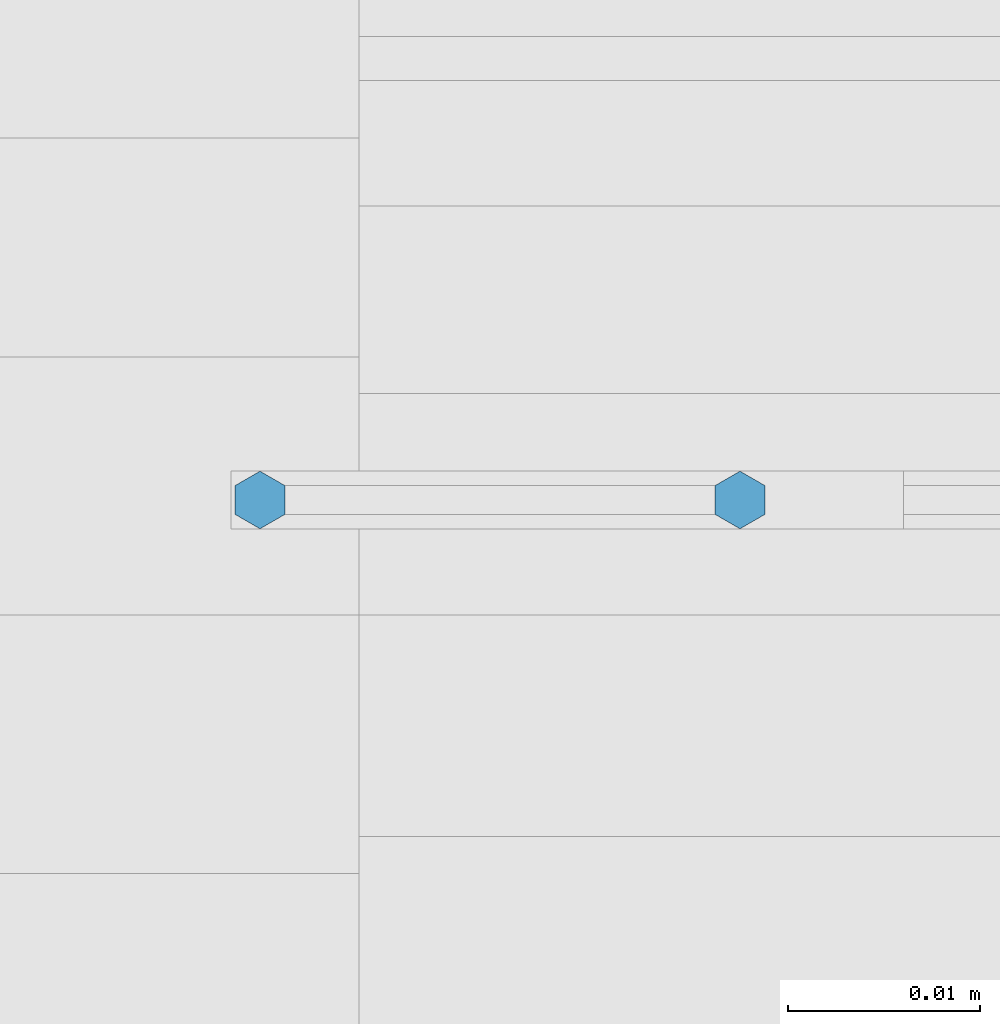
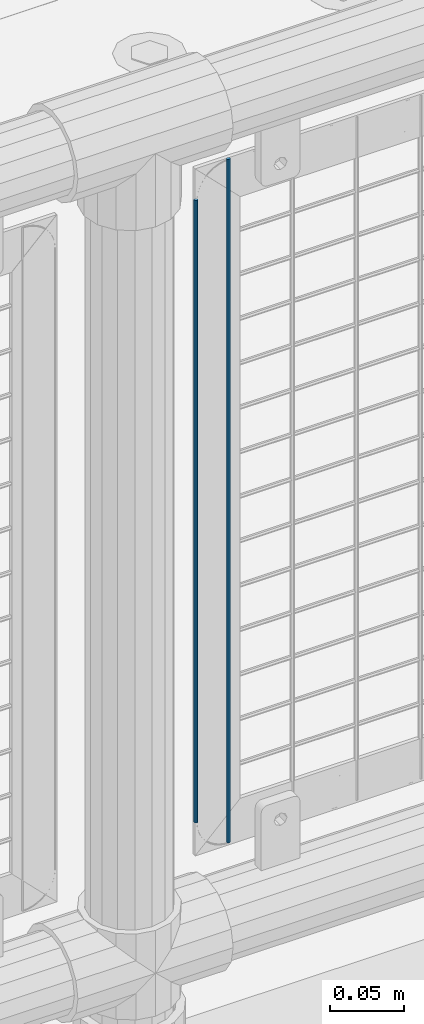
# One storey, part 69 of 208: 2 columns.
"""IFC2X3 building model written with IfcOpenShell, lengths in millimetres."""

from ifc_helpers import new_model, si_unit, frame, origin_with_axes, place, context, subcontext, project, spatial, faceted_brep, material, type_object, element, save


model = new_model("IFC2X3")

# Units and contexts
model_context = context("Model", 3, precision=1e-05, world=origin_with_axes())
body_context = subcontext(model_context, "Body", "Model", "MODEL_VIEW")
ifc_project = project(units=[si_unit("LENGTHUNIT", "METRE", prefix="MILLI"), si_unit("AREAUNIT", "SQUARE_METRE"), si_unit("VOLUMEUNIT", "CUBIC_METRE"), si_unit("MASSUNIT", "GRAM", prefix="KILO"), si_unit("TIMEUNIT", "SECOND"), si_unit("PLANEANGLEUNIT", "RADIAN"), si_unit("SOLIDANGLEUNIT", "STERADIAN"), si_unit("THERMODYNAMICTEMPERATUREUNIT", "DEGREE_CELSIUS"), si_unit("LUMINOUSINTENSITYUNIT", "LUMEN")], contexts=[model_context])

# Site, building, storey
site_placement = place(None, origin_with_axes())
site = spatial("IfcSite", under=ifc_project, at=site_placement, CompositionType="ELEMENT")
building_placement = place(site_placement, origin_with_axes())
building = spatial("IfcBuilding", under=site, at=building_placement, Name="Standard", CompositionType="ELEMENT")
storey_placement = place(building_placement, origin_with_axes())
storey = spatial("IfcBuildingStorey", under=building, at=storey_placement, Name="Undefined", CompositionType="ELEMENT", Elevation=0.0)

# Columns
ifc_material = material(Name="Misc_Undefined")
column_type = type_object("IfcColumnType", Name="D3", PredefinedType="NOTDEFINED")
column_1_placement = place(storey_placement, frame((-35374.0, 4670.5, 378.020000000002), z_axis=(-1.0, 0.0, 0.0), x_axis=(0.0, 0.0, 1.0)))
element("IfcColumn", 1, at=column_1_placement, inside=storey, type_object=column_type, material=ifc_material, ObjectType="D3", context=body_context, shape_type="Brep", body=[
    faceted_brep([(0.0, -1.49999999999909, 3.63797880709171e-12), (-7.27595761418343e-12, -0.749999999999091, -1.29903810567669), (510.0, -0.75, -1.29903810567703), (510.0, -1.5, 0.0), (-3.63797880709171e-12, 0.750000000000909, -1.29903810567669), (510.0, 0.75, -1.29903810567703), (0.0, 1.50000000000182, 3.63797880709171e-12), (510.0, 1.5, 0.0), (-3.63797880709171e-12, 0.750000000000909, 1.29903810567669), (510.0, 0.75, 1.29903810567703), (-7.27595761418343e-12, -0.749999999999091, 1.29903810567669), (510.0, -0.75, 1.29903810567703)], [[[0, 1, 2, 3]], [[1, 4, 5, 2]], [[4, 6, 7, 5]], [[6, 8, 9, 7]], [[8, 10, 11, 9]], [[10, 0, 3, 11]], [[5, 7, 9, 11, 3, 2]], [[10, 8, 6, 4, 1, 0]]]),
])
column_2_placement = place(storey_placement, frame((-35349.0, 4670.5, 353.020000000002), z_axis=(-1.0, 0.0, 0.0), x_axis=(0.0, 0.0, 1.0)))
element("IfcColumn", 2, at=column_2_placement, inside=storey, type_object=column_type, material=ifc_material, ObjectType="D3", context=body_context, shape_type="Brep", body=[
    faceted_brep([(0.0, -1.49999999999909, 3.63797880709171e-12), (-7.27595761418343e-12, -0.749999999999091, -1.29903810567669), (560.0, -0.75, -1.29903810567703), (560.0, -1.5, 0.0), (-3.63797880709171e-12, 0.750000000000909, -1.29903810567669), (560.0, 0.75, -1.29903810567703), (0.0, 1.50000000000182, 3.63797880709171e-12), (560.0, 1.5, 0.0), (-3.63797880709171e-12, 0.750000000000909, 1.29903810567669), (560.0, 0.75, 1.29903810567703), (-7.27595761418343e-12, -0.749999999999091, 1.29903810567669), (560.0, -0.75, 1.29903810567703)], [[[0, 1, 2, 3]], [[1, 4, 5, 2]], [[4, 6, 7, 5]], [[6, 8, 9, 7]], [[8, 10, 11, 9]], [[10, 0, 3, 11]], [[5, 7, 9, 11, 3, 2]], [[10, 8, 6, 4, 1, 0]]]),
])

save(model, "model.ifc")
